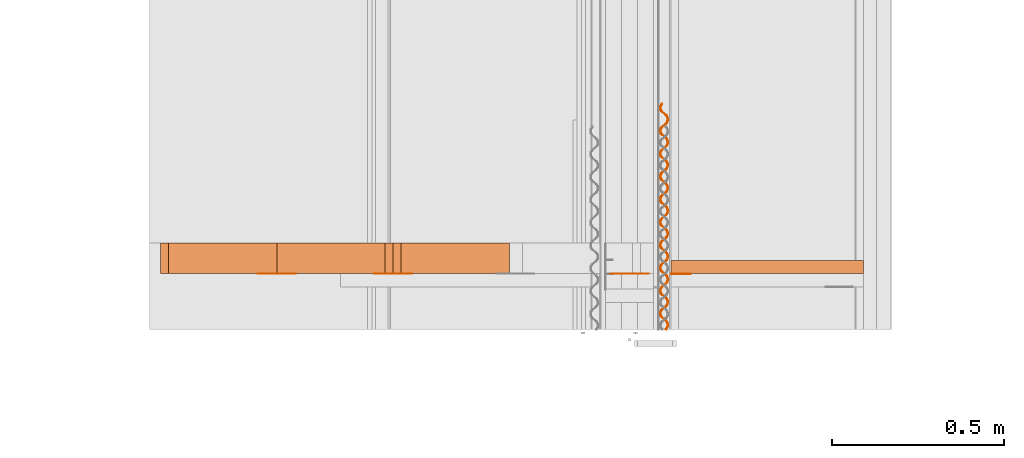
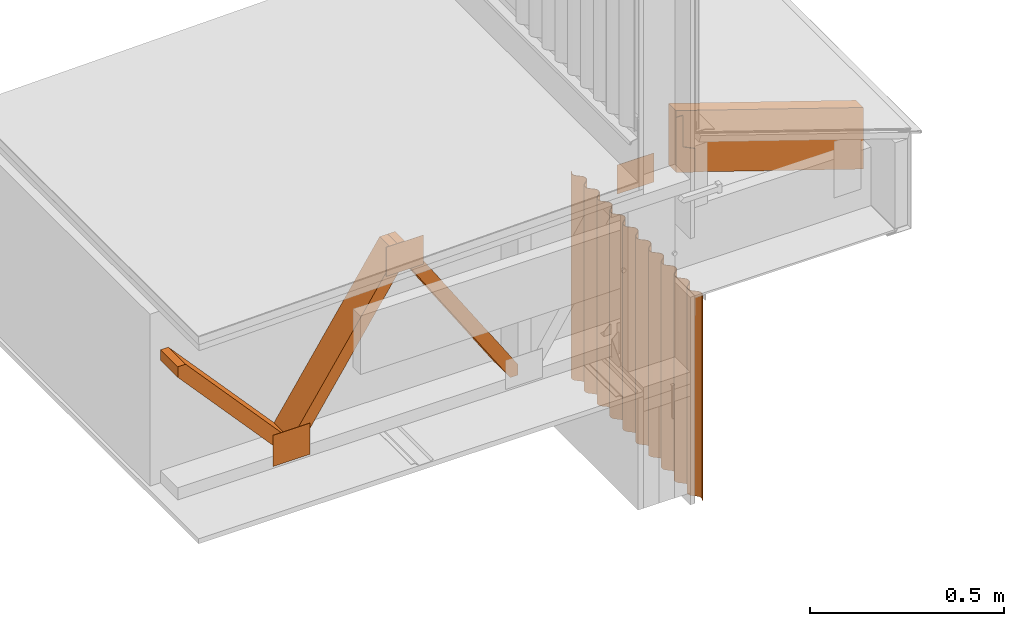
# One storey, part 9 of 22: 9 proxies.
"""IFC2X3 building model written with IfcOpenShell, lengths in feet."""

from ifc_helpers import new_model, entity, si_unit, converted_unit, frame, frame_2d, origin_with_axes, place, context, subcontext, project, spatial, polyline, rectangle, outline, extrude, source, transform, mapped, type_object, type_shapes, element, save


model = new_model("IFC2X3")

# Units and contexts
model_context = context("Model", 3, precision=1e-05)
plan_context = context("Plan", 2, precision=1e-05, world=frame_2d((0.0, 0.0, 0.0), x_axis=(1.0, 0.0, 0.0)))
body_context_1 = subcontext(model_context, "Body", "Model", "MODEL_VIEW")
body_context_2 = subcontext(model_context, "Body", "Model", "MODEL_VIEW")
ifc_project = project(units=[converted_unit("VOLUMEUNIT", "cubic foot", entity("IfcReal", 0.0283168467116885), si_unit("VOLUMEUNIT", "CUBIC_METRE"), dimensions=[3, 0, 0, 0, 0, 0, 0]), converted_unit("AREAUNIT", "square foot", entity("IfcReal", 0.09290304), si_unit("AREAUNIT", "SQUARE_METRE"), dimensions=[2, 0, 0, 0, 0, 0, 0]), converted_unit("LENGTHUNIT", "foot", entity("IfcReal", 0.3048), si_unit("LENGTHUNIT", "METRE"), dimensions=[1, 0, 0, 0, 0, 0, 0])], contexts=[model_context, plan_context])

# Site, building, storey
site_placement = place(None, origin_with_axes())
site = spatial("IfcSite", under=ifc_project, at=site_placement, CompositionType="ELEMENT")
building_placement = place(site_placement, origin_with_axes())
building = spatial("IfcBuilding", under=site, at=building_placement, Name="Building", CompositionType="ELEMENT")
storey_placement = place(building_placement, origin_with_axes())
storey = spatial("IfcBuildingStorey", under=building, at=storey_placement, Name="Storey", CompositionType="ELEMENT")

# Proxies
building_element_proxy_type = type_object("IfcBuildingElementProxyType", Name="Joist Hanger", PredefinedType="NOTDEFINED")
shared_shape = source(origin_with_axes(), body_context_1, "Body", "SweptSolid", [
    extrude(outline(polyline([(-0.00881109224128833, 0.0180805950203123), (0.318028888325366, 0.0180805950203123), (0.318028863881204, 0.0837614657137338), (-0.249296426773071, 0.0837614840468553), (-0.31098948297851, -0.101166228541317), (-0.0669608159073851, -0.102517886815734), (-0.00881109224128833, 0.0180805950203123)])), frame((0.0837614901578958, 3.25657088420332e-10, -0.318028863881204), z_axis=(-3.43235848939245e-17, -1.0, -7.41326279461618e-17), x_axis=(1.86973476701269e-08, -6.96530478824931e-17, 1.0)), (3.00694551924607e-07, 1.20495053579361e-06, -1.0), 0.00520833370861658),
])
type_shapes(building_element_proxy_type, [shared_shape])
proxy_1_placement = place(storey_placement, frame((1616.13434318482, 2.41967304328608, -59.3933283187586), z_axis=(0.0, 0.0, 1.0), x_axis=(1.0, 0.0, 0.0)))
element("IfcBuildingElementProxy", 1, at=proxy_1_placement, inside=storey, type_object=building_element_proxy_type, context=body_context_1, shape_type="MappedRepresentation", body=[
    mapped(shared_shape, transform((0.0, 0.0, 0.0), x_axis=(1.0, 0.0, 0.0), y_axis=(0.0, 1.0, 0.0), z_axis=(0.0, 0.0, 1.0), scale=1.0)),
])
proxy_2_placement = place(storey_placement, frame((1612.31544074111, 2.42211120178693, -61.4758739321251), z_axis=(0.0, 0.0, 1.0), x_axis=(1.0, 0.0, 0.0)))
element("IfcBuildingElementProxy", 2, at=proxy_2_placement, inside=storey, Name="Generic Models 852:Generic Models 1", context=body_context_1, shape_type="SweptSolid", body=[
    extrude(rectangle(XDim=0.360930176725411, YDim=0.00277022707595213, at=frame_2d((0.0, 0.0, 0.0))), frame((3.42311743363308, 0.00138511354766121, 1.4904025071875), z_axis=(0.0, 0.0, -1.0), x_axis=(-1.0, 0.0, 0.0)), (0.0, 0.0, -1.0), 0.301264218204712),
])
proxy_3_placement = place(storey_placement, frame((1620.31669316329, 2.54990880101372, -61.3518837555813), z_axis=(4.72560586217696e-08, -1.0, 1.84752977361313e-07), x_axis=(0.948875963687897, -1.34769821968916e-08, -0.315649151802063)))
element("IfcBuildingElementProxy", 3, at=proxy_3_placement, inside=storey, Name="Generic Models 857:Generic Models 1", context=body_context_1, shape_type="SweptSolid", body=[
    extrude(outline(polyline([(-0.0133190372484563, -0.916683259285654), (0.62322640043544, -0.916683357062302), (0.0133188936390041, 0.916684237052136), (-0.623226595988737, 0.916684334828785), (-0.0133190372484563, -0.916683259285654)])), frame((-3.54205764184787, 0.301954138466692, 2.74812477469546e-05), z_axis=(1.12182533484884e-07, 2.97551991934597e-07, -1.0), x_axis=(0.315661638975143, -0.948871791362762, -2.39389265743739e-07)), (1.91164440366265e-06, -5.72479757465771e-06, -1.0), 0.12500000023739),
])
proxy_4_placement = place(storey_placement, frame((1616.04803691073, 1.89104789667555, -60.8998145957006), z_axis=(-5.64259664770361e-07, -8.02678698619275e-07, 1.0), x_axis=(1.0, 3.25841369885893e-07, 5.64259948987456e-07)))
element("IfcBuildingElementProxy", 4, at=proxy_4_placement, inside=storey, Name="Generic Models 1:Generic Models 1", context=body_context_2, shape_type="SweptSolid", body=[
    extrude(outline(polyline([(0.160822994381268, -7.37621687264658e-09), (0.174598245248394, 0.00336361333075177), (0.187122798341466, 0.0100290967124634), (0.197659368844326, 0.0195072495117001), (0.205531501238115, 0.0313236353689135), (0.225829248979023, 0.0716311663995421), (0.232286883268769, 0.0812470353162038), (0.240907874789451, 0.089020651625836), (0.251155405297993, 0.0945117454144742), (0.262432083917728, 0.0972652397169842), (0.274057140735191, 0.0971149631196589), (0.285290724297208, 0.09418935136102), (0.295459422383096, 0.0886332544344147), (0.332043606426146, 0.0622150429531814), (0.344481969403783, 0.0553579727221975), (0.358194826547242, 0.0518009865905826), (0.372381827102246, 0.0516578843548229), (0.386156992414805, 0.0550214682761922), (0.398681838837821, 0.0616870551636526), (0.409218177121142, 0.0711650834504388), (0.417090395069498, 0.0829815319458174), (0.437382178434863, 0.123287602437763), (0.443845850432639, 0.132904974670391), (0.452466670844186, 0.140678572646902), (0.462714494682672, 0.146169733656986), (0.473991222190732, 0.148923246292617), (0.485615936789926, 0.148772865807603), (0.496849447019457, 0.145847266271045), (0.507018267326155, 0.140291157122359), (0.54360262247834, 0.113873006751531), (0.556040692126031, 0.107015844854939), (0.569753867043598, 0.103458962611013), (0.583940818710277, 0.103315842042132), (0.597715984022836, 0.106679395408299), (0.61024043933926, 0.113344853963908), (0.620770984356172, 0.122821562265943), (0.628649240012557, 0.134639459077924), (0.64894112115457, 0.174945572347153), (0.655404646487374, 0.184562871247295), (0.664025662452217, 0.192336493667968), (0.674273046295787, 0.197827544679323), (0.685549773803846, 0.200581069537035), (0.697174928397957, 0.200430762384507), (0.708408438627488, 0.19750517507003), (0.718577014492566, 0.191949041477182), (0.755161565198047, 0.165530891106354), (0.767593523805223, 0.1586722870042), (0.78131251643336, 0.155116798077512), (0.795499761429984, 0.154973750841117), (0.809274975630868, 0.158337353095608), (0.821799528723939, 0.165002811651217), (0.832329878187555, 0.174479422176604), (0.840208231620588, 0.18629738009899), (0.860499917209305, 0.226603420035733), (0.866963735872053, 0.236220804490442), (0.875584605171924, 0.243994390244872), (0.885832086792142, 0.249485453478308), (0.897108765411878, 0.252238990558101), (0.908733920005989, 0.252088707849735), (0.919967381347196, 0.249163083869015), (0.930135957212273, 0.243606974720329), (0.966720361252782, 0.217188799905339), (0.979152368748282, 0.210330208025266), (0.992871508041392, 0.206774706876497), (1.00705870414969, 0.206631659640102), (1.02083386946225, 0.209995249672512), (1.033358373667, 0.216660708228121), (1.04388891868391, 0.226137392085994), (1.05176081885816, 0.237953797804089), (1.04712913903039, 0.240223951579079), (1.03996123072356, 0.22950709315892), (1.03038244360075, 0.220881163917501), (1.01897278873939, 0.214900215232153), (1.00644368903218, 0.211840857240784), (0.993561322294821, 0.211890307780639), (0.981091181906502, 0.215132336995107), (0.969790743561242, 0.221339663065325), (0.933176615419663, 0.247853634551441), (0.921876274851051, 0.254060960621659), (0.909405938909435, 0.257302989836127), (0.896523865502025, 0.257352464820143), (0.883994765794809, 0.254293155717099), (0.872584915380152, 0.248312109255102), (0.863006128257341, 0.239686277790332), (0.855838219950518, 0.228969321593525), (0.835570196310679, 0.188566030558013), (0.828402288003856, 0.177849184359935), (0.818823647546017, 0.169223279562679), (0.807413797131361, 0.163242245322763), (0.794890808464661, 0.160184427313604), (0.782008588392278, 0.160233865631378), (0.769532190298471, 0.163474415974041), (0.758231947506507, 0.169681790932583), (0.72161772158828, 0.196195750196618), (0.710317429907992, 0.20240312515516), (0.697847142854701, 0.205645093259223), (0.684964922782317, 0.205694543799077), (0.67243592085175, 0.202635234696033), (0.661026070437093, 0.196654212678198), (0.65144738109093, 0.188028356769266), (0.644279521672432, 0.177311449460783), (0.624011204702648, 0.136908060648623), (0.616843345284149, 0.126191238894707), (0.607264802602958, 0.117565382985775), (0.595854952188302, 0.111584336523778), (0.583331767968305, 0.108526481848376), (0.57044964567257, 0.108575993498636), (0.557973589797032, 0.11181655606338), (0.546672907010151, 0.118023821023193), (0.510064889909088, 0.144539320269438), (0.498764353787179, 0.150746609673412), (0.486288200134993, 0.153987196682319), (0.47340598006261, 0.154036635000092), (0.46087683146707, 0.150977301452886), (0.449466981052414, 0.144996242768808), (0.439894402746766, 0.136371877953762), (0.432726592216592, 0.125655019533603), (0.412452359759589, 0.0852501762937999), (0.405284475896928, 0.0745333239846812), (0.395705786550765, 0.0659074558536681), (0.384302144953272, 0.059927906596598), (0.371772996357733, 0.0568685913825129), (0.358890678508701, 0.0569180174782051), (0.346414475968191, 0.0601586044871119), (0.335114062067092, 0.0663659061131671), (0.298505971633543, 0.0928813748042102), (0.287205728841579, 0.0990887742069137), (0.27472930630361, 0.102329257328132), (0.261846939566254, 0.102378701756945), (0.249317937635687, 0.0993193926539008), (0.237908331662651, 0.09333841341335), (0.228335508915383, 0.0847139691547772), (0.22116747838775, 0.0739970801794154), (0.200893502594448, 0.0335922949944972), (0.193725630953869, 0.022875448796419), (0.184153003759897, 0.0142510427318494), (0.172743055568592, 0.00826996953405068), (0.160214151414673, 0.00521067838218757), (0.147331784677318, 0.00526015985918444), (0.134855594358888, 0.00850065825800375), (0.123555009348655, 0.0147080064807429), (0.0869471328015246, 0.041223487393867), (0.0756466455679397, 0.0474308348527261), (0.0631703574728621, 0.0506713057518631), (0.0502880854566344, 0.0507208143466023), (0.0377652434549072, 0.0476630146705651), (0.0263553899847303, 0.0416819590420078), (0.0167765066130307, 0.0330560511892314), (0.0096088282341074, 0.0223392324908355), (-0.0106593840841077, -0.0180641318771626), (-0.0178271441981979, -0.0287810116859637), (-0.0274057495175541, -0.0374067942624095), (-0.0388155907656499, -0.0433879201679327), (-0.0513447974160744, -0.0464471864936937), (-0.0642271641534301, -0.046397766509042), (-0.0766972862086271, -0.0431557984049786), (-0.0879977673311715, -0.036948432612998), (-0.124611913805871, -0.0104344168218376), (-0.135912486594024, -0.0042271575911259), (-0.148388603579967, -0.000986529237210623), (-0.161270652543216, -0.000937104478308545), (-0.173793408990376, -0.00399481850429353), (-0.185203454958329, -0.00997593677101603), (-0.194782144304492, -0.0186018133047098), (-0.201950211498368, -0.0293186915857507), (-0.222218015140749, -0.0697220284540666), (-0.229385996780058, -0.0804389113183879), (-0.238964881679517, -0.0890648100046035), (-0.250374634317526, -0.0950458259113974), (-0.262903734024741, -0.0981051839027661), (-0.2757859052088, -0.0980556539193852), (-0.288256021152957, -0.0948136613711597), (-0.299556630607352, -0.0886063291899019), (-0.336170660972282, -0.0620923393706637), (-0.347471148205867, -0.0558850010783654), (-0.359941166373375, -0.0526429413086942), (-0.372823655331542, -0.0525935091019615), (-0.38535243726465, -0.0556528365381277), (-0.3967626787859, -0.0616339318884483), (-0.40634097702547, -0.0702596961317726), (-0.413509227550562, -0.0809766889948232), (-0.433776957860456, -0.121379906697849), (-0.440944817278955, -0.132096777340089), (-0.450523506625118, -0.140722682137345), (-0.461933601481395, -0.146703728599342), (-0.474456639036419, -0.149761571052663), (-0.48733895688545, -0.149712169401133), (-0.499815110537637, -0.146471533503902), (-0.511115255552953, -0.140264170767441), (-0.547729481471179, -0.113750235947568), (-0.559030066481413, -0.107542885433188), (-0.571500206869731, -0.104300905107044), (-0.584382475830439, -0.104251430123028), (-0.596911379984358, -0.107310678115667), (-0.608321328175662, -0.113291810132231), (-0.617900017521826, -0.121917653819082), (-0.625067436945407, -0.132634365574269), (-0.645335900580163, -0.173037864385158), (-0.652503906663634, -0.183754747249479), (-0.662082547121474, -0.192380603158411), (-0.673492299759482, -0.19836167406457), (-0.686015337314506, -0.201419492073729), (-0.698897606275213, -0.201370078200117), (-0.711373808815723, -0.198129527857454), (-0.722673904942715, -0.191922079566426), (-0.759282459815343, -0.165406702540991), (-0.770582360389039, -0.159199193139558), (-0.783059149589438, -0.155958838350191), (-0.795941222996849, -0.155909265589526), (-0.808470322704065, -0.158968623580895), (-0.819879879788777, -0.164949584488324), (-0.829452898089341, -0.173574010413776), (-0.836620708619516, -0.184290991054745), (-0.856894892188195, -0.224695724295819), (-0.864062800495017, -0.235412631604302), (-0.873635232135693, -0.244036923086862), (-0.885045180326997, -0.250018042881345), (-0.897574280034213, -0.253077351984389), (-0.91045654899492, -0.253027950332859), (-0.922932751535431, -0.249787387768115), (-0.934232896550747, -0.243579939477087), (-0.970841255870078, -0.217064550229571), (-0.98206885061239, -0.210942460952468), (-0.994485018290873, -0.207687231890486), (-1.0073239721964, -0.207524164885361), (-1.01982207670612, -0.210472913043393), (-1.03118919872549, -0.216443521848188), (-1.04077346134061, -0.224967641154612), (-1.04798947575837, -0.23559315174114), (-1.04351795408044, -0.238314789189441), (-1.03706039312318, -0.228698895828618), (-1.02843903494006, -0.220925138965054), (-1.0181912599899, -0.21543410017578), (-1.00691487470011, -0.212680685316797), (-0.995290013435944, -0.212830992469325), (-0.984056258764793, -0.215756518673396), (-0.973887878453012, -0.221312627822082), (-0.937303669965799, -0.247730924857883), (-0.924865404764811, -0.25458802564407), (-0.911152425400541, -0.258144920110077), (-0.896965522622186, -0.258288040678958), (-0.883189672873089, -0.254924377314062), (-0.870665657551583, -0.248258943202614), (-0.860129050382479, -0.23878081713918), (-0.852256954654934, -0.226964411421085), (-0.831964877959624, -0.186658249263532), (-0.825501059296876, -0.177040889252984), (-0.81687989666706, -0.169267279054393), (-0.806632903930083, -0.163776362485929), (-0.795356323086996, -0.161022813184055), (-0.783731266269534, -0.16117308367034), (-0.772497756040002, -0.164098707651059), (-0.762329326839898, -0.169654829021827), (-0.725744140586202, -0.196072857171845), (-0.713306510933428, -0.202930104623004), (-0.699593287127537, -0.206486999089011), (-0.685406531014155, -0.206630168546216), (-0.671631365701595, -0.203266566291725), (-0.659106519278579, -0.196601009959467), (-0.648576218703287, -0.187124436100324), (-0.640697425275337, -0.175306343735047), (-0.620405935239917, -0.135000438241195), (-0.613942556572086, -0.125383078230648), (-0.605321345053946, -0.117609406921651), (-0.595074156763672, -0.11211840479862), (-0.583797380367289, -0.10936490438507), (-0.572171932443233, -0.109515052650544), (-0.560938862208619, -0.11244085996248), (-0.550769797460301, -0.117996810224113), (-0.514185588973088, -0.144414985039103), (-0.501753728142561, -0.151273662473742), (-0.488034833291071, -0.154829175844593), (-0.473847490517799, -0.154972210858907), (-0.460072227428591, -0.151608608604416), (-0.447547772112168, -0.14494318671505), (-0.437017373760228, -0.135466527301339), (-0.429139264768816, -0.123648581601034), (-0.408847383626803, -0.0833425477753318), (-0.402383687184864, -0.0737252183199867), (-0.39376289121748, -0.0659516264545167), (-0.383515214043965, -0.0604605143327569), (-0.37223853542423, -0.0577069650308823), (-0.360613087500174, -0.057857211073005), (-0.349379772823939, -0.0607828044985223), (-0.339211148070538, -0.0663389808686543), (-0.302627037359974, -0.092757149572604), (-0.290194858755339, -0.0996157903410005), (-0.276475792794716, -0.103171267045608), (-0.262288352244795, -0.103314253171598), (-0.248513578038829, -0.0999507303606337), (-0.235988633839164, -0.0932852106946191), (-0.225458211043062, -0.0838085757250704), (-0.217580322049108, -0.0719907216903732), (-0.197288550905825, -0.0316846542539481), (-0.190824866685967, -0.0220672866045998), (-0.182204144051069, -0.0142937482107343), (-0.171962345698531, -0.0088040408644131), (-0.160679311596659, -0.0060489764064306), (-0.149054438110412, -0.00619929654491953), (-0.137821208988744, -0.00912500111498623), (-0.127658365279671, -0.0146825310805925), (-0.0910681801948335, -0.0410992804953824), (-0.0786359282577132, -0.0479578601533738), (-0.0649167522983601, -0.0515132788030964), (-0.0507298984083291, -0.0516564115940586), (-0.0369545375424733, -0.0482927726733247), (-0.0244299783383611, -0.0416273324508367), (-0.0138997663731572, -0.0321507524806527), (-0.00602732651764307, -0.0203342856521525), (0.0142703032037952, 0.019973220934314), (0.0207279313825012, 0.0295891051285771), (0.0293489412363042, 0.0373627153271687), (0.0395966092432578, 0.042853833559969), (0.0508792461274959, 0.0456088342339661), (0.0625043151670397, 0.0454585454145598), (0.0737316715787715, 0.0425314517285958), (0.083900369664659, 0.0369753823016729), (0.120490860301522, 0.0105586313591229), (0.132922818908698, 0.0037000142710083), (0.146635932715859, 0.000143101113810805), (0.160822994381268, -7.37621687264658e-09)])), frame((0.019423386174941, 1.07818808690144, -2.11772213144878), z_axis=(0.00018042691226583, -1.52014905552278e-07, -1.0), x_axis=(0.237208306789398, -0.971458792686462, 8.02529903012328e-05)), (-4.9348334869137e-05, -0.000319627666613087, -0.99999988079071), 2.1177161759931),
])
proxy_5_placement = place(storey_placement, frame((1612.0699384394, 2.42488121423196, -61.9758708583401), z_axis=(0.0, 0.0, 1.0), x_axis=(1.0, 0.0, 0.0)))
element("IfcBuildingElementProxy", 5, at=proxy_5_placement, inside=storey, Name="Generic Models 855:Generic Models 1", context=body_context_1, shape_type="SweptSolid", body=[
    extrude(outline(polyline([(-0.960161405911283, -0.061873820783898), (0.911361178544563, -0.06187384522806), (1.00224897304545, -0.00176692181059069), (0.960161308134635, 0.0618736496747635), (-0.911361276321211, 0.06187384522806), (-1.0022490708221, 0.00176672625729418), (-0.960161405911283, -0.061873820783898)])), frame((0.859770405636685, 2.21605038198473e-07, 1.29333445484557), z_axis=(1.26847365944371e-09, -1.0, -3.13384944661266e-08), x_axis=(0.551616847515106, -2.51583696098123e-08, 0.834097623825073)), (1.42458731033912e-07, -1.83448864987668e-08, -1.0), 0.291666664589757),
])
proxy_6_placement = place(storey_placement, frame((1612.0699384394, 2.42488121423196, -61.9758708583401), z_axis=(0.0, 0.0, 1.0), x_axis=(1.0, 0.0, 0.0)))
element("IfcBuildingElementProxy", 6, at=proxy_6_placement, inside=storey, Name="Generic Models 855:Generic Models 1", context=body_context_1, shape_type="SweptSolid", body=[
    extrude(outline(polyline([(-0.834998789578285, -0.554331018542993), (-0.726033559465033, -0.554331018542993), (0.834998887354933, 0.478032575504673), (0.834998985131582, 0.554331018542993), (0.726033559465033, 0.554331018542993), (-0.834998789578285, -0.478032379951377), (-0.834998789578285, -0.554331018542993)])), frame((1.96849032649844, 2.46049200261872e-07, 1.29333386818568), z_axis=(0.0, -1.0, 0.0), x_axis=(0.0, 0.0, -1.0)), (0.0, 0.0, -1.0), 0.291666664589754),
])
proxy_7_placement = place(storey_placement, frame((1612.19499242587, 2.42211120178693, -61.6217035008228), z_axis=(0.0, 0.0, 1.0), x_axis=(1.0, 0.0, 0.0)))
element("IfcBuildingElementProxy", 7, at=proxy_7_placement, inside=storey, Name="Generic Models 852:Generic Models 1", context=body_context_1, shape_type="SweptSolid", body=[
    extrude(rectangle(XDim=0.360930148950862, YDim=0.00277022707595213, at=frame_2d((0.0, 0.0, 0.0))), frame((0.180465076363149, 0.00138511354766121, 0.0), z_axis=(0.0, 0.0, -1.0), x_axis=(1.0, 0.0, 0.0)), (0.0, 0.0, -1.0), 0.322097519461289),
])
proxy_8_placement = place(storey_placement, frame((1612.19499242587, 2.42211120178693, -61.5350405375163), z_axis=(0.0, 0.0, 1.0), x_axis=(1.0, 0.0, 0.0)))
element("IfcBuildingElementProxy", 8, at=proxy_8_placement, inside=storey, Name="Generic Models 852:Generic Models 1", context=body_context_1, shape_type="SweptSolid", body=[
    extrude(rectangle(XDim=0.360930176725411, YDim=0.00277022707595213, at=frame_2d((0.0, 0.0, 0.0))), frame((1.28912702789457, 0.00138511354766121, 1.4904025071875), z_axis=(0.0, 0.0, -1.0), x_axis=(-1.0, 0.0, 0.0)), (0.0, 0.0, -1.0), 0.301264218204712),
])
proxy_9_placement = place(storey_placement, frame((1609.85260810752, 2.42488121423196, -61.9758708583401), z_axis=(0.0, 0.0, 1.0), x_axis=(1.0, 0.0, 0.0)))
element("IfcBuildingElementProxy", 9, at=proxy_9_placement, inside=storey, Name="Generic Models 855:Generic Models 1", context=body_context_1, shape_type="SweptSolid", body=[
    extrude(outline(polyline([(-0.624998699961685, -0.554331018542993), (-0.516033567625081, -0.554331018542993), (0.624999042179954, 0.478032575504673), (0.624999091068278, 0.554331018542993), (0.516033665401729, 0.554331018542993), (-0.624998699961685, -0.478032379951377), (-0.624998699961685, -0.554331018542993)])), frame((1.96849032649844, 2.46049200261872e-07, 1.08333397412238), z_axis=(0.0, -1.0, 0.0), x_axis=(0.0, 0.0, -1.0)), (3.35234233261872e-07, 0.0, -1.0), 0.291666664589771),
])

save(model, "model.ifc")
